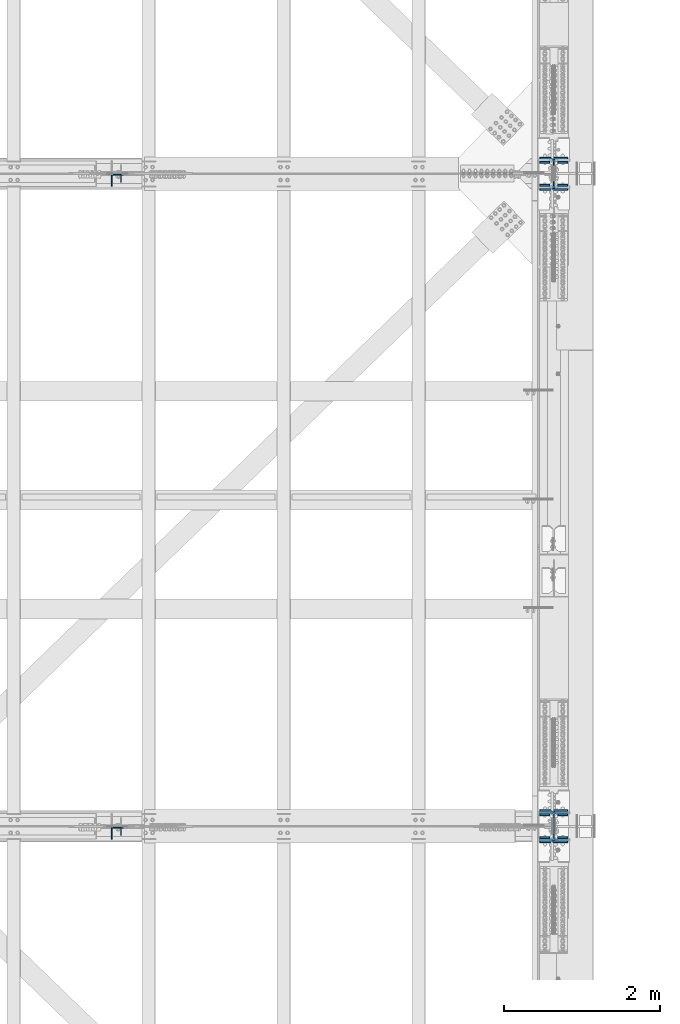
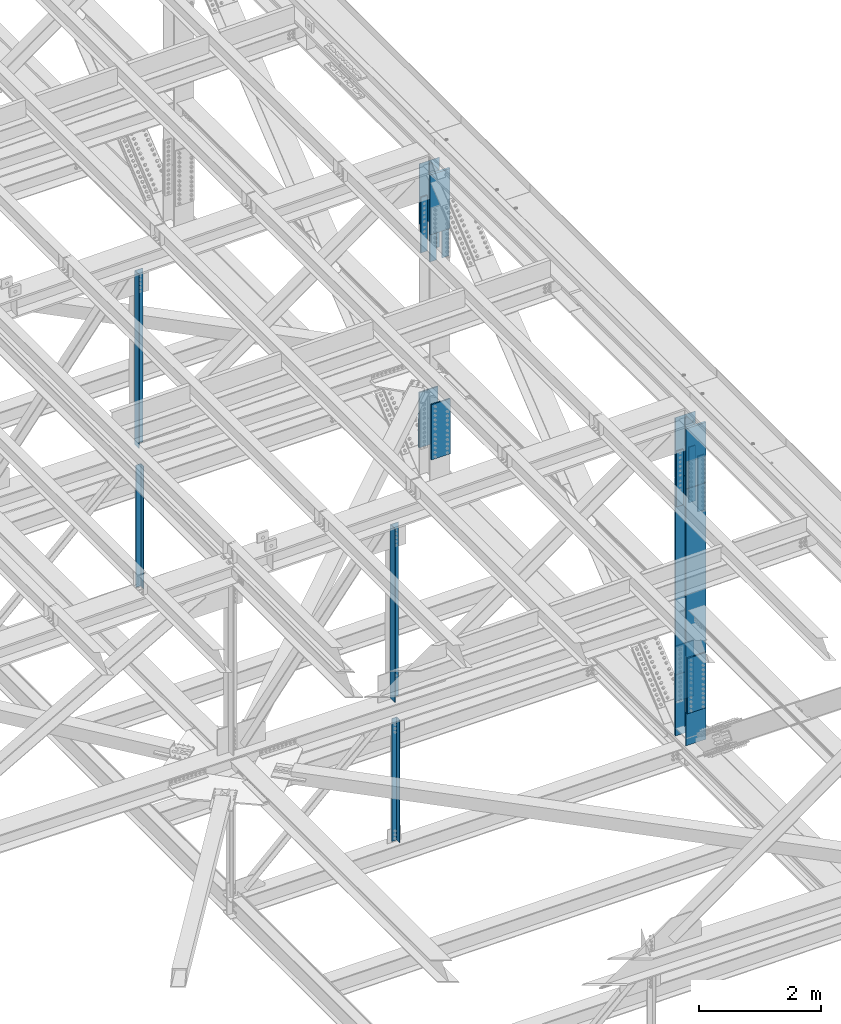
# One storey, part 1419 of 3843: 20 columns, 9 elements without a shape of their own.
"""IFC2X3 building model written with IfcOpenShell, lengths in millimetres."""

from ifc_helpers import new_model, si_unit, frame, origin_with_axes, place, context, subcontext, project, spatial, faceted_brep, material, type_object, element, aggregate, save


model = new_model("IFC2X3")

# Units and contexts
model_context = context("Model", 3, precision=1e-05, world=origin_with_axes())
body_context = subcontext(model_context, "Body", "Model", "MODEL_VIEW")
ifc_project = project(units=[si_unit("LENGTHUNIT", "METRE", prefix="MILLI"), si_unit("AREAUNIT", "SQUARE_METRE"), si_unit("VOLUMEUNIT", "CUBIC_METRE"), si_unit("MASSUNIT", "GRAM", prefix="KILO"), si_unit("TIMEUNIT", "SECOND"), si_unit("PLANEANGLEUNIT", "RADIAN"), si_unit("SOLIDANGLEUNIT", "STERADIAN"), si_unit("THERMODYNAMICTEMPERATUREUNIT", "DEGREE_CELSIUS"), si_unit("LUMINOUSINTENSITYUNIT", "LUMEN")], contexts=[model_context])

# Site, building, storey
site_placement = place(None, origin_with_axes())
site = spatial("IfcSite", under=ifc_project, at=site_placement, CompositionType="ELEMENT")
building_placement = place(site_placement, origin_with_axes())
building = spatial("IfcBuilding", under=site, at=building_placement, Name="Undefined", CompositionType="ELEMENT")
storey_placement = place(building_placement, origin_with_axes())
storey = spatial("IfcBuildingStorey", under=building, at=storey_placement, Name="Undefined", CompositionType="ELEMENT", Elevation=0.0)

# Assembly, column
assembly_1_placement = place(storey_placement, origin_with_axes())
assembly_1 = element("IfcElementAssembly", 1, at=assembly_1_placement, inside=storey, Name="ANGLE", AssemblyPlace="NOTDEFINED", PredefinedType="RIGID_FRAME")
ifc_material_1 = material(Name="STEEL/A572-50")
column_type_1 = type_object("IfcColumnType", Name="L4X4X3/8", PredefinedType="NOTDEFINED")
column_1_placement = place(assembly_1_placement, frame((80060.7999999924, 67211.575, 39471.5297055045), z_axis=(-1.0, 0.0, 0.0), x_axis=(0.0, 0.0, 1.0)))
column_1 = element("IfcColumn", 2, at=column_1_placement, type_object=column_type_1, material=ifc_material_1, Name="ANGLE", ObjectType="L4X4X3/8", context=body_context, shape_type="Brep", body=[
    faceted_brep([(203.615019024095, 50.8000000000029, -50.8000000000029), (203.615019024095, 50.8000000000029, 50.8000000000029), (2642.96331364066, 50.8000000000029, 50.8000000000029), (2642.96331364066, 50.8000000000029, -50.8000000000029), (203.615019024095, 41.2749999999942, 50.8000000000029), (2642.96331364066, 41.2749999999942, 50.8000000000029), (203.615019024095, 41.2749999999942, -41.2749999999942), (2642.96331364066, 41.2749999999942, -41.2749999999942), (203.615019024095, -50.8000000000029, -41.2749999999942), (2642.96331364066, -50.8000000000029, -41.2749999999942), (203.615019024095, -50.8000000000029, -50.8000000000029), (2642.96331364066, -50.8000000000029, -50.8000000000029)], [[[0, 1, 2, 3]], [[1, 4, 5, 2]], [[4, 6, 7, 5]], [[6, 8, 9, 7]], [[8, 10, 11, 9]], [[10, 0, 3, 11]], [[5, 7, 9, 11, 3, 2]], [[10, 8, 6, 4, 1, 0]]]),
])
aggregate(assembly_1, [column_1])

assembly_2_placement = place(storey_placement, origin_with_axes())
assembly_2 = element("IfcElementAssembly", 3, at=assembly_2_placement, inside=storey, Name="ANGLE", AssemblyPlace="NOTDEFINED", PredefinedType="RIGID_FRAME")
column_2_placement = place(assembly_2_placement, frame((80060.7999999579, 58854.975, 39473.6759375242), z_axis=(-1.0, 0.0, 0.0), x_axis=(0.0, 0.0, 1.0)))
column_2 = element("IfcColumn", 4, at=column_2_placement, type_object=column_type_1, material=ifc_material_1, Name="ANGLE", ObjectType="L4X4X3/8", context=body_context, shape_type="Brep", body=[
    faceted_brep([(203.650779188371, 50.8000000000029, -50.8000000000029), (203.650779188371, 50.8000000000029, 50.8000000000029), (2654.52087037371, 50.8000000000029, 50.8000000000029), (2654.52087037371, 50.8000000000029, -50.8000000000029), (203.650779188371, 41.2750000000015, 50.8000000000029), (2654.52087037371, 41.2750000000015, 50.8000000000029), (203.650779188371, 41.2750000000015, -41.2749999999942), (2654.52087037371, 41.2750000000015, -41.2749999999942), (203.650779188371, -50.8000000000029, -41.2749999999942), (2654.52087037371, -50.8000000000029, -41.2749999999942), (203.650779188371, -50.8000000000029, -50.8000000000029), (2654.52087037371, -50.8000000000029, -50.8000000000029)], [[[0, 1, 2, 3]], [[1, 4, 5, 2]], [[4, 6, 7, 5]], [[6, 8, 9, 7]], [[8, 10, 11, 9]], [[10, 0, 3, 11]], [[5, 7, 9, 11, 3, 2]], [[10, 8, 6, 4, 1, 0]]]),
])
aggregate(assembly_2, [column_2])

# Assembly, columns
assembly_3_placement = place(storey_placement, origin_with_axes())
assembly_3 = element("IfcElementAssembly", 5, at=assembly_3_placement, inside=storey, Name="BEAM", AssemblyPlace="NOTDEFINED", PredefinedType="RIGID_FRAME")
column_type_2 = type_object("IfcColumnType", PredefinedType="NOTDEFINED")
column_3_placement = place(assembly_3_placement, frame((85534.5, 67124.2625205291, 44339.3959599932), z_axis=(1.0, 0.0, 0.0), x_axis=(0.0, 0.0, 1.0)))
column_3 = element("IfcColumn", 6, at=column_3_placement, type_object=column_type_2, material=ifc_material_1, Name="PLATE", context=body_context, shape_type="Brep", body=[
    faceted_brep([(-4.36557456851006e-11, 12.7000000000116, -63.5), (-4.36557456851006e-11, 12.7000000000116, 63.5), (1104.90000001677, 12.7000000017251, 63.5), (1104.90000001677, 12.7000000017251, -63.5), (1.45519152283669e-11, -12.700000000008, 63.5), (1104.90000001682, -12.6999999982909, 63.5), (1.45519152283669e-11, -12.700000000008, -63.5), (1104.90000001682, -12.6999999982909, -63.5)], [[[0, 1, 2, 3]], [[1, 4, 5, 2]], [[4, 6, 7, 5]], [[6, 0, 3, 7]], [[5, 7, 3, 2]], [[6, 4, 1, 0]]]),
])
column_4_placement = place(assembly_3_placement, frame((85534.5, 67419.5375000017, 44339.3959599932), z_axis=(1.0, 0.0, 0.0), x_axis=(0.0, 0.0, 1.0)))
column_4 = element("IfcColumn", 7, at=column_4_placement, type_object=column_type_2, material=ifc_material_1, Name="PLATE", context=body_context, shape_type="Brep", body=[
    faceted_brep([(-4.36557456851006e-11, 12.7000000000116, -63.5), (-4.36557456851006e-11, 12.7000000000116, 63.5), (1104.90000001677, 12.7000000017251, 63.5), (1104.90000001677, 12.7000000017251, -63.5), (1.45519152283669e-11, -12.700000000008, 63.5), (1104.90000001682, -12.6999999982909, 63.5), (1.45519152283669e-11, -12.700000000008, -63.5), (1104.90000001682, -12.6999999982909, -63.5)], [[[0, 1, 2, 3]], [[1, 4, 5, 2]], [[4, 6, 7, 5]], [[6, 0, 3, 7]], [[5, 7, 3, 2]], [[6, 4, 1, 0]]]),
])
column_5_placement = place(assembly_3_placement, frame((85763.1, 67124.2625205291, 44339.3959599932), z_axis=(1.0, 0.0, 0.0), x_axis=(0.0, 0.0, 1.0)))
column_5 = element("IfcColumn", 8, at=column_5_placement, type_object=column_type_2, material=ifc_material_1, Name="PLATE", context=body_context, shape_type="Brep", body=[
    faceted_brep([(-4.36557456851006e-11, 12.7000000000116, -63.5), (-4.36557456851006e-11, 12.7000000000116, 63.5), (1104.90000001677, 12.7000000017251, 63.5), (1104.90000001677, 12.7000000017251, -63.5), (1.45519152283669e-11, -12.700000000008, 63.5), (1104.90000001682, -12.6999999982909, 63.5), (1.45519152283669e-11, -12.700000000008, -63.5), (1104.90000001682, -12.6999999982909, -63.5)], [[[0, 1, 2, 3]], [[1, 4, 5, 2]], [[4, 6, 7, 5]], [[6, 0, 3, 7]], [[5, 7, 3, 2]], [[6, 4, 1, 0]]]),
])
column_6_placement = place(assembly_3_placement, frame((85763.1, 67419.5375000013, 44339.3959599932), z_axis=(1.0, 0.0, 0.0), x_axis=(0.0, 0.0, 1.0)))
column_6 = element("IfcColumn", 9, at=column_6_placement, type_object=column_type_2, material=ifc_material_1, Name="PLATE", context=body_context, shape_type="Brep", body=[
    faceted_brep([(-4.36557456851006e-11, 12.7000000000116, -63.5), (-4.36557456851006e-11, 12.7000000000116, 63.5), (1104.90000001677, 12.7000000017251, 63.5), (1104.90000001677, 12.7000000017251, -63.5), (1.45519152283669e-11, -12.700000000008, 63.5), (1104.90000001682, -12.6999999982909, 63.5), (1.45519152283669e-11, -12.700000000008, -63.5), (1104.90000001682, -12.6999999982909, -63.5)], [[[0, 1, 2, 3]], [[1, 4, 5, 2]], [[4, 6, 7, 5]], [[6, 0, 3, 7]], [[5, 7, 3, 2]], [[6, 4, 1, 0]]]),
])

assembly_4_placement = place(storey_placement, origin_with_axes())
assembly_4 = element("IfcElementAssembly", 10, at=assembly_4_placement, inside=storey, Name="BEAM", AssemblyPlace="NOTDEFINED", PredefinedType="RIGID_FRAME")
column_7_placement = place(assembly_4_placement, frame((85534.5, 58767.6625357562, 44345.2298081518), z_axis=(1.0, 0.0, 0.0), x_axis=(0.0, 0.0, 1.0)))
column_7 = element("IfcColumn", 11, at=column_7_placement, type_object=column_type_2, material=ifc_material_1, Name="PLATE", context=body_context, shape_type="Brep", body=[
    faceted_brep([(-4.36557456851006e-11, 12.7000000000116, -63.5), (-4.36557456851006e-11, 12.7000000000116, 63.5), (1104.90000001677, 12.7000000017251, 63.5), (1104.90000001677, 12.7000000017251, -63.5), (1.45519152283669e-11, -12.700000000008, 63.5), (1104.90000001682, -12.6999999982909, 63.5), (1.45519152283669e-11, -12.700000000008, -63.5), (1104.90000001682, -12.6999999982909, -63.5)], [[[0, 1, 2, 3]], [[1, 4, 5, 2]], [[4, 6, 7, 5]], [[6, 0, 3, 7]], [[5, 7, 3, 2]], [[6, 4, 1, 0]]]),
])
column_8_placement = place(assembly_4_placement, frame((85534.5, 59062.9375286225, 44345.2298122853), z_axis=(1.0, 0.0, 0.0), x_axis=(0.0, 0.0, 1.0)))
column_8 = element("IfcColumn", 12, at=column_8_placement, type_object=column_type_2, material=ifc_material_1, Name="PLATE", context=body_context, shape_type="Brep", body=[
    faceted_brep([(-4.36557456851006e-11, 12.7000000000116, -63.5), (-4.36557456851006e-11, 12.7000000000116, 63.5), (1104.90000001677, 12.7000000017251, 63.5), (1104.90000001677, 12.7000000017251, -63.5), (1.45519152283669e-11, -12.700000000008, 63.5), (1104.90000001682, -12.6999999982909, 63.5), (1.45519152283669e-11, -12.700000000008, -63.5), (1104.90000001682, -12.6999999982909, -63.5)], [[[0, 1, 2, 3]], [[1, 4, 5, 2]], [[4, 6, 7, 5]], [[6, 0, 3, 7]], [[5, 7, 3, 2]], [[6, 4, 1, 0]]]),
])
column_9_placement = place(assembly_4_placement, frame((85763.1, 58767.6625357562, 44345.2298081518), z_axis=(1.0, 0.0, 0.0), x_axis=(0.0, 0.0, 1.0)))
column_9 = element("IfcColumn", 13, at=column_9_placement, type_object=column_type_2, material=ifc_material_1, Name="PLATE", context=body_context, shape_type="Brep", body=[
    faceted_brep([(-4.36557456851006e-11, 12.7000000000116, -63.5), (-4.36557456851006e-11, 12.7000000000116, 63.5), (1104.90000001677, 12.7000000017251, 63.5), (1104.90000001677, 12.7000000017251, -63.5), (1.45519152283669e-11, -12.700000000008, 63.5), (1104.90000001682, -12.6999999982909, 63.5), (1.45519152283669e-11, -12.700000000008, -63.5), (1104.90000001682, -12.6999999982909, -63.5)], [[[0, 1, 2, 3]], [[1, 4, 5, 2]], [[4, 6, 7, 5]], [[6, 0, 3, 7]], [[5, 7, 3, 2]], [[6, 4, 1, 0]]]),
])
column_10_placement = place(assembly_4_placement, frame((85763.1, 59062.9375280741, 44345.2298122853), z_axis=(1.0, 0.0, 0.0), x_axis=(0.0, 0.0, 1.0)))
column_10 = element("IfcColumn", 14, at=column_10_placement, type_object=column_type_2, material=ifc_material_1, Name="PLATE", context=body_context, shape_type="Brep", body=[
    faceted_brep([(-4.36557456851006e-11, 12.7000000000116, -63.5), (-4.36557456851006e-11, 12.7000000000116, 63.5), (1104.90000001677, 12.7000000017251, 63.5), (1104.90000001677, 12.7000000017251, -63.5), (1.45519152283669e-11, -12.700000000008, 63.5), (1104.90000001682, -12.6999999982909, 63.5), (1.45519152283669e-11, -12.700000000008, -63.5), (1104.90000001682, -12.6999999982909, -63.5)], [[[0, 1, 2, 3]], [[1, 4, 5, 2]], [[4, 6, 7, 5]], [[6, 0, 3, 7]], [[5, 7, 3, 2]], [[6, 4, 1, 0]]]),
])

# Assembly, column
assembly_5_placement = place(storey_placement, origin_with_axes())
assembly_5 = element("IfcElementAssembly", 15, at=assembly_5_placement, inside=storey, Name="ANGLE", AssemblyPlace="NOTDEFINED", PredefinedType="RIGID_FRAME")
column_type_3 = type_object("IfcColumnType", Name="L6X6X1/2", PredefinedType="NOTDEFINED")
column_11_placement = place(assembly_5_placement, frame((80060.8, 67186.175, 42332.026452477), z_axis=(0.0, -1.0, 0.0), x_axis=(0.0, 0.0, 1.0)))
column_11 = element("IfcColumn", 16, at=column_11_placement, type_object=column_type_3, material=ifc_material_1, Name="ANGLE", ObjectType="L6X6X1/2", context=body_context, shape_type="Brep", body=[
    faceted_brep([(208.708766025287, 76.1999999999971, -76.1999999999971), (208.708766025287, 76.1999999999971, 76.1999999999971), (3670.48818055919, 76.1999999999971, 76.1999999999971), (3670.48818055919, 76.1999999999971, -76.1999999999971), (208.708766025287, 63.5, 76.1999999999971), (3670.48818055919, 63.5, 76.1999999999971), (208.708766025287, 63.5, -63.5), (3670.48818055919, 63.5, -63.5), (208.708766025287, -76.1999999999971, -63.5), (3670.48818055919, -76.1999999999971, -63.5), (208.708766025287, -76.1999999999971, -76.1999999999971), (3670.48818055919, -76.1999999999971, -76.1999999999971)], [[[0, 1, 2, 3]], [[1, 4, 5, 2]], [[4, 6, 7, 5]], [[6, 8, 9, 7]], [[8, 10, 11, 9]], [[10, 0, 3, 11]], [[5, 7, 9, 11, 3, 2]], [[10, 8, 6, 4, 1, 0]]]),
])
aggregate(assembly_5, [column_11])

assembly_6_placement = place(storey_placement, origin_with_axes())
assembly_6 = element("IfcElementAssembly", 17, at=assembly_6_placement, inside=storey, Name="ANGLE", AssemblyPlace="NOTDEFINED", PredefinedType="RIGID_FRAME")
column_12_placement = place(assembly_6_placement, frame((80060.7999997531, 58829.575, 42337.1940566244), z_axis=(0.0, -1.0, 0.0), x_axis=(0.0, 0.0, 1.0)))
column_12 = element("IfcColumn", 18, at=column_12_placement, type_object=column_type_3, material=ifc_material_1, Name="ANGLE", ObjectType="L6X6X1/2", context=body_context, shape_type="Brep", body=[
    faceted_brep([(211.188163840248, 76.1999999999971, -76.1999999999971), (211.188163840248, 76.1999999999971, 76.1999999999971), (3670.51501143636, 76.1999999999971, 76.1999999999971), (3670.51501143636, 76.1999999999971, -76.1999999999971), (211.188163840248, 63.5, 76.1999999999971), (3670.51501143636, 63.5, 76.1999999999971), (211.188163840248, 63.5, -63.5), (3670.51501143636, 63.5, -63.5), (211.188163840248, -76.1999999999971, -63.5), (3670.51501143636, -76.1999999999971, -63.5), (211.188163840248, -76.1999999999971, -76.1999999999971), (3670.51501143636, -76.1999999999971, -76.1999999999971)], [[[0, 1, 2, 3]], [[1, 4, 5, 2]], [[4, 6, 7, 5]], [[6, 8, 9, 7]], [[8, 10, 11, 9]], [[10, 0, 3, 11]], [[5, 7, 9, 11, 3, 2]], [[10, 8, 6, 4, 1, 0]]]),
])
aggregate(assembly_6, [column_12])

# Assembly, columns
assembly_7_placement = place(storey_placement, origin_with_axes())
assembly_7 = element("IfcElementAssembly", 19, at=assembly_7_placement, inside=storey, Name="BEAM", AssemblyPlace="NOTDEFINED", PredefinedType="RIGID_FRAME")
column_type_4 = type_object("IfcColumnType", PredefinedType="NOTDEFINED")
column_13_placement = place(assembly_7_placement, frame((85648.8, 67073.4620738109, 40421.3285661284), z_axis=(-1.0, 0.0, 0.0), x_axis=(0.0, 0.0, 1.0)))
column_13 = element("IfcColumn", 20, at=column_13_placement, type_object=column_type_4, material=ifc_material_1, Name="PLATE", context=body_context, shape_type="Brep", body=[
    faceted_brep([(-1.45519152283669e-11, 12.7000000000025, -177.800000000003), (-1.45519152283669e-11, 12.7000000000025, 177.800000000003), (1104.90000001682, 12.7000000017051, 177.800000000003), (1104.90000001682, 12.7000000017051, -177.800000000003), (4.36557456851006e-11, -12.7000000000171, 177.800000000003), (1104.90000001686, -12.6999999983072, 177.800000000003), (4.36557456851006e-11, -12.7000000000171, -177.800000000003), (1104.90000001686, -12.6999999983072, -177.800000000003)], [[[0, 1, 2, 3]], [[1, 4, 5, 2]], [[4, 6, 7, 5]], [[6, 0, 3, 7]], [[5, 7, 3, 2]], [[6, 4, 1, 0]]]),
])
column_14_placement = place(assembly_7_placement, frame((85648.8, 67470.3375848499, 40421.3285276303), z_axis=(-1.0, 0.0, 0.0), x_axis=(0.0, 0.0, 1.0)))
column_14 = element("IfcColumn", 21, at=column_14_placement, type_object=column_type_4, material=ifc_material_1, Name="PLATE", context=body_context, shape_type="Brep", body=[
    faceted_brep([(-1.45519152283669e-11, 12.7000000000025, -177.800000000003), (-1.45519152283669e-11, 12.7000000000025, 177.800000000003), (1104.90000001682, 12.7000000017051, 177.800000000003), (1104.90000001682, 12.7000000017051, -177.800000000003), (4.36557456851006e-11, -12.7000000000171, 177.800000000003), (1104.90000001686, -12.6999999983072, 177.800000000003), (4.36557456851006e-11, -12.7000000000171, -177.800000000003), (1104.90000001686, -12.6999999983072, -177.800000000003)], [[[0, 1, 2, 3]], [[1, 4, 5, 2]], [[4, 6, 7, 5]], [[6, 0, 3, 7]], [[5, 7, 3, 2]], [[6, 4, 1, 0]]]),
])
aggregate(assembly_7, [column_13, column_14])

assembly_8_placement = place(storey_placement, origin_with_axes())
assembly_8 = element("IfcElementAssembly", 22, at=assembly_8_placement, inside=storey, Name="BEAM", AssemblyPlace="NOTDEFINED", PredefinedType="RIGID_FRAME")
column_15_placement = place(assembly_8_placement, frame((85648.8, 58716.8620910583, 40427.2793693721), z_axis=(-1.0, 0.0, 0.0), x_axis=(0.0, 0.0, 1.0)))
column_15 = element("IfcColumn", 23, at=column_15_placement, type_object=column_type_4, material=ifc_material_1, Name="PLATE", context=body_context, shape_type="Brep", body=[
    faceted_brep([(-1.45519152283669e-11, 12.7000000000025, -177.800000000003), (-1.45519152283669e-11, 12.7000000000025, 177.800000000003), (1104.90000001682, 12.7000000017051, 177.800000000003), (1104.90000001682, 12.7000000017051, -177.800000000003), (4.36557456851006e-11, -12.7000000000171, 177.800000000003), (1104.90000001686, -12.6999999983072, 177.800000000003), (4.36557456851006e-11, -12.7000000000171, -177.800000000003), (1104.90000001686, -12.6999999983072, -177.800000000003)], [[[0, 1, 2, 3]], [[1, 4, 5, 2]], [[4, 6, 7, 5]], [[6, 0, 3, 7]], [[5, 7, 3, 2]], [[6, 4, 1, 0]]]),
])
column_16_placement = place(assembly_8_placement, frame((85648.8, 59113.7375813494, 40427.2793324622), z_axis=(-1.0, 0.0, 0.0), x_axis=(0.0, 0.0, 1.0)))
column_16 = element("IfcColumn", 24, at=column_16_placement, type_object=column_type_4, material=ifc_material_1, Name="PLATE", context=body_context, shape_type="Brep", body=[
    faceted_brep([(-1.45519152283669e-11, 12.7000000000025, -177.800000000003), (-1.45519152283669e-11, 12.7000000000025, 177.800000000003), (1104.90000001682, 12.7000000017051, 177.800000000003), (1104.90000001682, 12.7000000017051, -177.800000000003), (4.36557456851006e-11, -12.7000000000171, 177.800000000003), (1104.90000001686, -12.6999999983072, 177.800000000003), (4.36557456851006e-11, -12.7000000000171, -177.800000000003), (1104.90000001686, -12.6999999983072, -177.800000000003)], [[[0, 1, 2, 3]], [[1, 4, 5, 2]], [[4, 6, 7, 5]], [[6, 0, 3, 7]], [[5, 7, 3, 2]], [[6, 4, 1, 0]]]),
])

# Column
ifc_material_2 = material(Name="STEEL/A992")
column_type_5 = type_object("IfcColumnType", Name="W14X132", PredefinedType="NOTDEFINED")
column_17_placement = place(assembly_3_placement, frame((85648.8, 67271.9000000013, 44891.8459599932), z_axis=(0.0, 1.0, 0.0), x_axis=(0.0, 0.0, 1.0)))
column_17 = element("IfcColumn", 25, at=column_17_placement, type_object=column_type_5, material=ifc_material_2, Name="COLUMN", ObjectType="W14X132", context=body_context, shape_type="Brep", body=[
    faceted_brep([(1163.39674588216, 187.324999999997, -160.337499999994), (6.34999999999854, 187.324999999997, -160.337499999994), (6.34999999999854, 7.9375, -160.337499999994), (1163.39674588216, 7.9375, -160.337499999994), (1216.18092717397, 7.9375, -160.337499999994), (1216.18092717397, 187.324999999997, -160.337499999994), (1163.17786881165, 187.324999999997, 160.337499999994), (6.34999999999854, 187.324999999997, 160.337499999994), (6.34999999999854, 187.324999999997, 185.737500000003), (1201.24486768747, 187.324999999997, 185.737500000003), (1215.76374544296, 187.324999999997, 160.337499999994), (1163.17786881165, 7.9375, 160.337499999994), (6.34999999999854, 7.9375, 160.337499999994), (1215.76374544296, 7.9375, 160.337499999994), (1203.44563150336, 7.9375, -131.766481032508), (1159.13034545651, 7.9375, -131.798955815626), (1153.95187995316, 7.9375, -133.334161120292), (1150.44082520707, 7.9375, -137.438531335909), (1149.72618168899, 7.9375, -142.792281884729), (1152.03774725931, 7.9375, -147.673882535222), (1151.80803767582, 7.9375, 147.717863044396), (1149.49797795214, 7.9375, 142.834749775648), (1150.21513156618, 7.9375, 137.480605416727), (1153.72883177955, 7.9375, 133.377547784548), (1158.90892495141, 7.9375, 131.845292631755), (1203.10959369139, 7.9375, 131.841580186854), (1153.95187995316, -7.9375, -133.334161120292), (1159.13034545651, -7.9375, -131.798955815626), (1150.44082520707, -7.9375, -137.438531335909), (1149.72618168899, -7.9375, -142.792281884729), (1152.03774725931, -7.9375, -147.673882535222), (1163.39674588216, -7.9375, -160.337499999994), (6.34999999999854, -187.324999999997, -185.737500000003), (6.34999999999854, 187.324999999997, -185.737500000003), (1201.52970035486, 187.324999999997, -185.737500000003), (1201.52970035486, -187.324999999997, -185.737500000003), (1163.39674588216, -187.324999999997, -160.337499999994), (6.34999999999854, -187.324999999997, -160.337499999994), (1216.18092717397, -187.324999999997, -160.251953007581), (6.34999999999854, -7.9375, -160.337499999994), (1216.18092717397, -7.9375, -160.337499999994), (6.34999999999854, -7.9375, 160.337499999994), (6.34999999999854, -187.324999999997, 160.337499999994), (6.34999999999854, -187.324999999997, 185.737500000003), (1163.17786881165, -187.324999999997, 160.337499999994), (1163.17786881165, -7.9375, 160.337499999994), (1215.76376483833, -7.9375, 160.412031279178), (1215.76374544296, -187.324999999997, 160.425715777514), (1201.24486768747, -187.324999999997, 185.737500000003), (1151.80803767582, -7.9375, 147.717863044396), (1149.49797795214, -7.9375, 142.834749775648), (1150.21513156618, -7.9375, 137.480605416727), (1153.72883177955, -7.9375, 133.377547784548), (1158.90892495141, -7.9375, 131.845292631755), (1215.97820017189, -7.9375, 131.840503170795), (1215.97820017223, -4.93760635516082, 131.840502610663), (1216.13667196505, -4.75284506284515, -131.757180882982), (1216.13667196505, -7.9375, -131.757180882982)], [[[0, 1, 2, 3, 4, 5]], [[6, 7, 8, 9, 10]], [[11, 12, 7, 6, 10, 13]], [[14, 15, 16, 17, 18, 19, 3, 2, 12, 11, 20, 21, 22, 23, 24, 25]], [[26, 16, 15, 27]], [[28, 17, 16, 26]], [[29, 18, 17, 28]], [[30, 19, 18, 29]], [[31, 3, 19, 30]], [[32, 33, 34, 35]], [[36, 37, 32, 35, 38]], [[31, 39, 37, 36, 38, 40]], [[3, 31, 40, 4]], [[38, 35, 34, 5, 4, 40]], [[33, 1, 0, 5, 34]], [[32, 37, 39, 41, 42, 43, 8, 7, 12, 2, 1, 33]], [[44, 42, 41, 45, 46, 47]], [[43, 42, 44, 47, 48]], [[8, 43, 48, 9]], [[47, 46, 13, 10, 9, 48]], [[45, 11, 13, 46]], [[49, 20, 11, 45]], [[50, 21, 20, 49]], [[51, 22, 21, 50]], [[52, 23, 22, 51]], [[53, 24, 23, 52]], [[25, 24, 53, 54, 55]], [[14, 25, 55, 56]], [[27, 15, 14, 56, 57]], [[53, 52, 51, 50, 49, 45, 41, 39, 31, 30, 29, 28, 26, 27, 57, 54]], [[56, 55, 54, 57]]]),
])

aggregate(assembly_3, [column_3, column_4, column_5, column_6, column_17])

column_18_placement = place(assembly_4_placement, frame((85648.8, 58915.3000203404, 44897.6798102186), z_axis=(0.0, 1.0, 0.0), x_axis=(0.0, 0.0, 1.0)))
column_18 = element("IfcColumn", 26, at=column_18_placement, type_object=column_type_5, material=ifc_material_2, Name="COLUMN", ObjectType="W14X132", context=body_context, shape_type="Brep", body=[
    faceted_brep([(1163.39674588216, 187.324999999997, -160.337499999994), (6.34999999999854, 187.324999999997, -160.337499999994), (6.34999999999854, 7.9375, -160.337499999994), (1163.39674588216, 7.9375, -160.337499999994), (1216.18092717397, 7.9375, -160.337499999994), (1216.18092717397, 187.324999999997, -160.337499999994), (1163.17786881165, 187.324999999997, 160.337499999994), (6.34999999999854, 187.324999999997, 160.337499999994), (6.34999999999854, 187.324999999997, 185.737500000003), (1201.24486768747, 187.324999999997, 185.737500000003), (1215.76374544296, 187.324999999997, 160.337499999994), (1163.17786881165, 7.9375, 160.337499999994), (6.34999999999854, 7.9375, 160.337499999994), (1215.76374544296, 7.9375, 160.337499999994), (1203.44563150336, 7.9375, -131.766481032508), (1159.13034545651, 7.9375, -131.798955815626), (1153.95187995316, 7.9375, -133.334161120292), (1150.44082520707, 7.9375, -137.438531335909), (1149.72618168899, 7.9375, -142.792281884729), (1152.03774725931, 7.9375, -147.673882535222), (1151.80803767582, 7.9375, 147.717863044396), (1149.49797795214, 7.9375, 142.834749775648), (1150.21513156618, 7.9375, 137.480605416727), (1153.72883177955, 7.9375, 133.377547784548), (1158.90892495141, 7.9375, 131.845292631755), (1203.10959369139, 7.9375, 131.841580186854), (1153.95187995316, -7.9375, -133.334161120292), (1159.13034545651, -7.9375, -131.798955815626), (1150.44082520707, -7.9375, -137.438531335909), (1149.72618168899, -7.9375, -142.792281884729), (1152.03774725931, -7.9375, -147.673882535222), (1163.39674588216, -7.9375, -160.337499999994), (6.34999999999854, -187.324999999997, -185.737500000003), (6.34999999999854, 187.324999999997, -185.737500000003), (1201.52970035486, 187.324999999997, -185.737500000003), (1201.52970035486, -187.324999999997, -185.737500000003), (1163.39674588216, -187.324999999997, -160.337499999994), (6.34999999999854, -187.324999999997, -160.337499999994), (1216.18092717397, -187.324999999997, -160.251953007581), (6.34999999999854, -7.9375, -160.337499999994), (1216.18092717397, -7.9375, -160.337499999994), (6.34999999999854, -7.9375, 160.337499999994), (6.34999999999854, -187.324999999997, 160.337499999994), (6.34999999999854, -187.324999999997, 185.737500000003), (1163.17786881165, -187.324999999997, 160.337499999994), (1163.17786881165, -7.9375, 160.337499999994), (1215.76376483833, -7.9375, 160.412031279178), (1215.76374544296, -187.324999999997, 160.425715777514), (1201.24486768747, -187.324999999997, 185.737500000003), (1151.80803767582, -7.9375, 147.717863044396), (1149.49797795214, -7.9375, 142.834749775648), (1150.21513156618, -7.9375, 137.480605416727), (1153.72883177955, -7.9375, 133.377547784548), (1158.90892495141, -7.9375, 131.845292631755), (1215.97820017189, -7.9375, 131.840503170795), (1215.97820017223, -4.93760635516082, 131.840502610663), (1216.13667196505, -4.75284506284515, -131.757180882982), (1216.13667196505, -7.9375, -131.757180882982)], [[[0, 1, 2, 3, 4, 5]], [[6, 7, 8, 9, 10]], [[11, 12, 7, 6, 10, 13]], [[14, 15, 16, 17, 18, 19, 3, 2, 12, 11, 20, 21, 22, 23, 24, 25]], [[26, 16, 15, 27]], [[28, 17, 16, 26]], [[29, 18, 17, 28]], [[30, 19, 18, 29]], [[31, 3, 19, 30]], [[32, 33, 34, 35]], [[36, 37, 32, 35, 38]], [[31, 39, 37, 36, 38, 40]], [[3, 31, 40, 4]], [[38, 35, 34, 5, 4, 40]], [[33, 1, 0, 5, 34]], [[32, 37, 39, 41, 42, 43, 8, 7, 12, 2, 1, 33]], [[44, 42, 41, 45, 46, 47]], [[43, 42, 44, 47, 48]], [[8, 43, 48, 9]], [[47, 46, 13, 10, 9, 48]], [[45, 11, 13, 46]], [[49, 20, 11, 45]], [[50, 21, 20, 49]], [[51, 22, 21, 50]], [[52, 23, 22, 51]], [[53, 24, 23, 52]], [[25, 24, 53, 54, 55]], [[14, 25, 55, 56]], [[27, 15, 14, 56, 57]], [[53, 52, 51, 50, 49, 45, 41, 39, 31, 30, 29, 28, 26, 27, 57, 54]], [[56, 55, 54, 57]]]),
])

aggregate(assembly_4, [column_7, column_8, column_9, column_10, column_18])

# Assembly, column
assembly_9_placement = place(storey_placement, origin_with_axes())
assembly_9 = element("IfcElementAssembly", 27, at=assembly_9_placement, inside=storey, Name="COLUMN", AssemblyPlace="NOTDEFINED", PredefinedType="RIGID_FRAME")
column_19_placement = place(assembly_9_placement, frame((85648.8, 58915.3001333623, 40979.7293509172), z_axis=(0.0, 1.0, 0.0), x_axis=(0.0, 0.0, 1.0)))
column_19 = element("IfcColumn", 28, at=column_19_placement, type_object=column_type_5, material=ifc_material_2, Name="COLUMN", ObjectType="W14X132", context=body_context, shape_type="Brep", body=[
    faceted_brep([(6.34999999999854, 187.324999999997, -185.737500000003), (6.34999999999854, 187.324999999997, -160.337499999994), (3911.60046170541, 187.324999999997, -160.337500007699), (3911.6004620864, 187.324999999997, -185.737500007701), (6.34999999999854, 7.9375, -160.337499999994), (3911.60046170541, 7.9375, -160.337500007699), (6.34999999999854, 7.9375, 160.337499999994), (3911.60045689528, 7.9375, 160.337499992296), (6.34999999999854, 187.324999999997, 160.337499999994), (3911.60045689528, 187.324999999997, 160.337499992296), (6.34999999999854, 187.324999999997, 185.737500000003), (3911.60045651428, 187.324999999997, 185.737499992298), (6.34999999999854, -187.324999999997, 185.737500000003), (3911.60045651428, -187.324999999997, 185.737499992298), (6.34999999999854, -187.324999999997, 160.337499999994), (3911.60045689528, -187.324999999997, 160.337499992296), (6.34999999999854, -7.9375, 160.337499999994), (3911.60045689528, -7.9375, 160.337499992296), (6.34999999999854, -7.9375, -160.337499999994), (3911.60046170541, -7.9375, -160.337500007699), (6.34999999999854, -187.324999999997, -160.337499999994), (3911.60046170541, -187.324999999997, -160.337500007699), (6.34999999999854, -187.324999999997, -185.737500000003), (3911.6004620864, -187.324999999997, -185.737500007701)], [[[0, 1, 2, 3]], [[1, 4, 5, 2]], [[4, 6, 7, 5]], [[6, 8, 9, 7]], [[8, 10, 11, 9]], [[10, 12, 13, 11]], [[12, 14, 15, 13]], [[14, 16, 17, 15]], [[16, 18, 19, 17]], [[18, 20, 21, 19]], [[20, 22, 23, 21]], [[22, 0, 3, 23]], [[5, 7, 9, 11, 13, 15, 17, 19, 21, 23, 3, 2]], [[22, 20, 18, 16, 14, 12, 10, 8, 6, 4, 1, 0]]]),
])
aggregate(assembly_9, [column_19])

# Column
column_20_placement = place(assembly_8_placement, frame((85648.8, 58915.3, 39552.5673070565), z_axis=(0.0, 1.0, 0.0), x_axis=(0.0, 0.0, 1.0)))
column_20 = element("IfcColumn", 29, at=column_20_placement, type_object=column_type_5, material=ifc_material_2, Name="COLUMN", ObjectType="W14X132", context=body_context, shape_type="Brep", body=[
    faceted_brep([(1420.81204386189, 187.324999999997, -185.737499998169), (1420.81204386189, -187.324999999997, -185.737499998169), (225.750130897723, -187.324999999997, -185.637660321197), (225.750130897723, 187.324999999997, -185.737499999705), (1420.8120438619, -187.324999999997, -160.337499998161), (263.867929611653, -187.324999999997, -160.337499999659), (211.0836845636, -187.324999999997, -160.337499999725), (1420.8120438619, -7.9375, -160.337499998161), (263.867929611653, -7.9375, -160.337499999659), (211.0836845636, -7.9375, -160.337499999725), (268.117150396742, -7.9375, -131.839019690444), (268.117150396742, 7.9375, -131.839019690444), (273.296537909511, 7.9375, -133.371111492292), (273.296537909511, -7.9375, -133.371111492292), (276.810059514508, 7.9375, -137.473370166234), (276.810059514508, -7.9375, -137.473370166234), (277.527921507877, 7.9375, -142.826690113252), (277.527921507877, -7.9375, -142.826690113252), (275.219291109432, 7.9375, -147.709679564403), (275.219291109432, -7.9375, -147.709679564403), (263.867929611653, 7.9375, -160.337499999659), (211.0836845636, 7.9375, -160.337499999725), (1420.8120438619, 7.9375, -160.337499998161), (1420.8120438619, 187.324999999997, -160.337499998161), (263.867929611653, 187.324999999997, -160.337499999659), (211.0836845636, 187.324999999997, -160.337499999725), (1420.8120438619, 7.9375, 160.337500001835), (1420.8120438619, 187.324999999997, 160.337500001835), (1420.8120438619, 187.324999999997, 185.737500001836), (1420.8120438619, -187.324999999997, 185.737500001836), (1420.8120438619, -187.324999999997, 160.337500001835), (1420.8120438619, -7.9375, 160.337500001835), (263.893938222056, 187.324999999997, 160.337500000343), (263.893938222056, 7.9375, 160.337500000343), (211.308078737842, 7.9375, 160.337500000278), (211.308078737842, 187.324999999997, 160.337500000278), (225.811635491387, 187.324999999997, 185.737500000294), (225.81163549138, -187.324999999997, 185.84051535678), (263.893938222056, -187.324999999997, 160.337500000343), (211.308078737842, -187.324999999997, 160.337500000278), (263.893938222056, -7.9375, 160.337500000343), (211.308078737842, -7.9375, 160.337500000278), (275.27141477124, 7.9375, 147.682150749606), (275.27141477124, -7.9375, 147.682150749606), (277.584409742267, 7.9375, 142.800427141454), (277.584409742267, -7.9375, 142.800427141454), (273.359242227431, -7.9375, 133.340683324568), (273.359242227431, 7.9375, 133.340683324568), (268.180071163741, 7.9375, 131.805314243386), (268.180071163741, -7.9375, 131.805314243386), (276.870475100433, -7.9375, 137.445852606572), (276.870475100433, 7.9375, 137.445852606572), (223.979412838467, -7.9375, 131.775028926641), (223.801852630182, -7.9375, -131.833186680509), (211.110809033591, 4.93773956580844, 131.766214708012), (211.110809033598, 4.75457611129968, -131.831517202852), (211.110809033598, 7.9375, -131.831517384453), (211.110809033591, 7.9375, 131.766215233489)], [[[0, 1, 2, 3]], [[1, 4, 5, 6, 2]], [[5, 4, 7, 8, 9, 6]], [[10, 11, 12, 13]], [[13, 12, 14, 15]], [[15, 14, 16, 17]], [[17, 16, 18, 19]], [[19, 18, 20, 8]], [[8, 20, 21, 9]], [[20, 22, 23, 24, 25, 21]], [[2, 6, 9, 21, 25, 3]], [[24, 23, 0, 3, 25]], [[22, 26, 27, 28, 29, 30, 31, 7, 4, 1, 0, 23]], [[32, 27, 26, 33, 34, 35]], [[28, 27, 32, 35, 36]], [[29, 28, 36, 37]], [[38, 30, 29, 37, 39]], [[40, 31, 30, 38, 39, 41]], [[37, 36, 35, 34, 41, 39]], [[33, 40, 41, 34]], [[40, 33, 42, 43]], [[43, 42, 44, 45]], [[46, 47, 48, 49]], [[50, 51, 47, 46]], [[45, 44, 51, 50]], [[46, 49, 52, 53, 10, 13, 15, 17, 19, 8, 7, 31, 40, 43, 45, 50]], [[53, 52, 54, 55]], [[11, 10, 53, 55, 56]], [[48, 47, 51, 44, 42, 33, 26, 22, 20, 18, 16, 14, 12, 11, 56, 57]], [[52, 49, 48, 57, 54]], [[56, 55, 54, 57]]]),
])

aggregate(assembly_8, [column_15, column_16, column_20])

save(model, "model.ifc")
